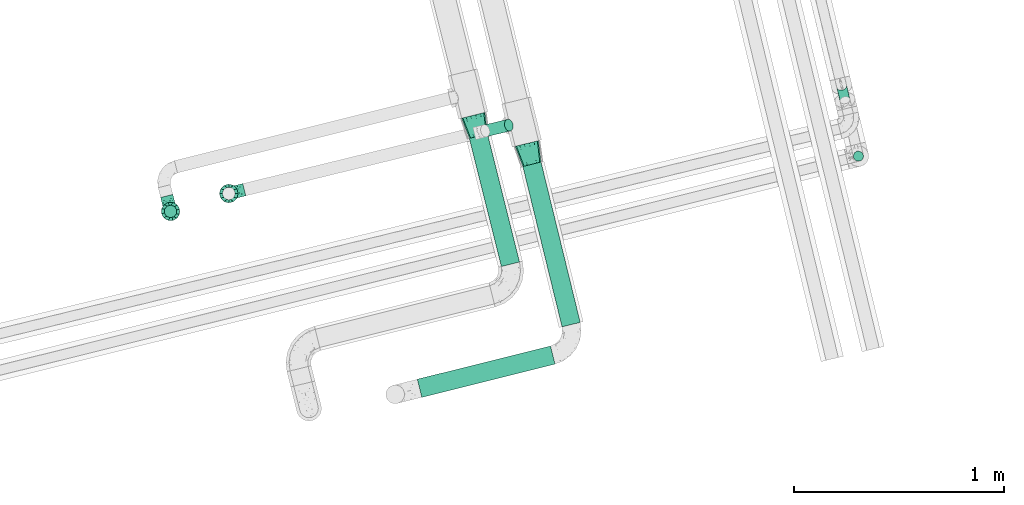
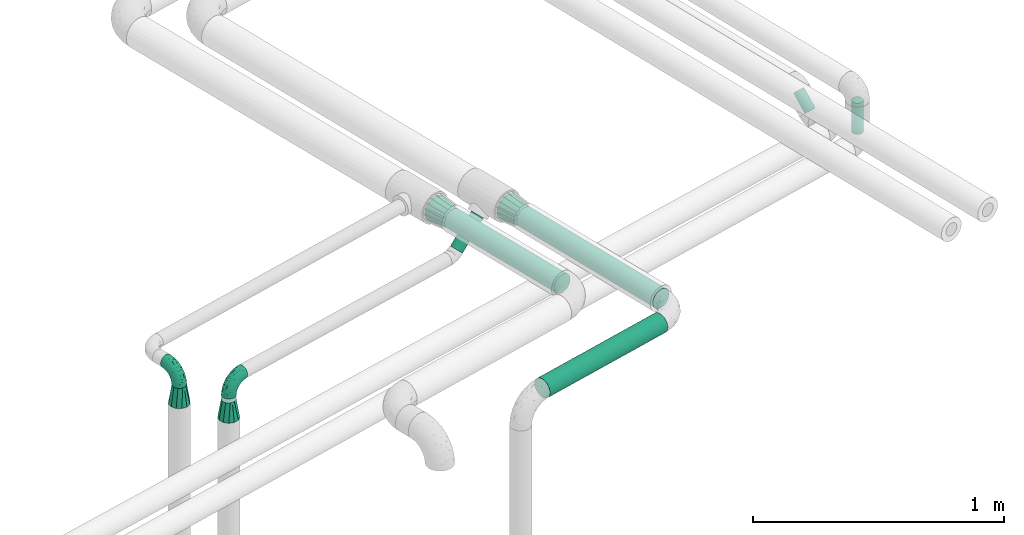
# One storey, part 49 of 93: 6 flow fittings, 6 flow segments.
"""IFC2X3 building model written with IfcOpenShell, lengths in millimetres."""

from ifc_helpers import new_model, entity, si_unit, converted_unit, derived_unit, direction, frame, origin, origin_2d_with_axis, place, context, subcontext, project, spatial, circle, extrude, faceted_brep, source, transform, mapped, material, type_object, type_shapes, element, save


model = new_model("IFC2X3")

# Units and contexts
model_context = context("Model", 3, precision=0.01, world=origin(), true_north=direction((6.12303176911189e-17, 1.0)))
body_context = subcontext(model_context, "Body", "Model", "MODEL_VIEW")
ifc_project = project(units=[si_unit("LENGTHUNIT", "METRE", prefix="MILLI"), si_unit("AREAUNIT", "SQUARE_METRE"), si_unit("VOLUMEUNIT", "CUBIC_METRE"), converted_unit("PLANEANGLEUNIT", "DEGREE", entity("IfcRatioMeasure", 0.0174532925199433), si_unit("PLANEANGLEUNIT", "RADIAN"), dimensions=[0, 0, 0, 0, 0, 0, 0]), si_unit("MASSUNIT", "GRAM", prefix="KILO"), derived_unit("MASSDENSITYUNIT", [(si_unit("MASSUNIT", "GRAM", prefix="KILO"), 1), (si_unit("LENGTHUNIT", "METRE"), -3)]), derived_unit("MOMENTOFINERTIAUNIT", [(si_unit("LENGTHUNIT", "METRE"), 4)]), si_unit("TIMEUNIT", "SECOND"), si_unit("FREQUENCYUNIT", "HERTZ"), si_unit("THERMODYNAMICTEMPERATUREUNIT", "DEGREE_CELSIUS"), derived_unit("THERMALTRANSMITTANCEUNIT", [(si_unit("MASSUNIT", "GRAM", prefix="KILO"), 1), (si_unit("THERMODYNAMICTEMPERATUREUNIT", "KELVIN"), -1), (si_unit("TIMEUNIT", "SECOND"), -3)]), derived_unit("VOLUMETRICFLOWRATEUNIT", [(si_unit("LENGTHUNIT", "METRE"), 3), (si_unit("TIMEUNIT", "SECOND"), -1)]), derived_unit("MASSFLOWRATEUNIT", [(si_unit("MASSUNIT", "GRAM", prefix="KILO"), 1), (si_unit("TIMEUNIT", "SECOND"), -1)]), derived_unit("ROTATIONALFREQUENCYUNIT", [(si_unit("TIMEUNIT", "SECOND"), -1)]), si_unit("ELECTRICCURRENTUNIT", "AMPERE"), si_unit("ELECTRICVOLTAGEUNIT", "VOLT"), si_unit("POWERUNIT", "WATT"), si_unit("FORCEUNIT", "NEWTON", prefix="KILO"), si_unit("ILLUMINANCEUNIT", "LUX"), si_unit("LUMINOUSFLUXUNIT", "LUMEN"), si_unit("LUMINOUSINTENSITYUNIT", "CANDELA"), derived_unit("USERDEFINED", [(si_unit("MASSUNIT", "GRAM", prefix="KILO"), -1), (si_unit("LENGTHUNIT", "METRE"), -2), (si_unit("TIMEUNIT", "SECOND"), 3), (si_unit("LUMINOUSFLUXUNIT", "LUMEN"), 1)]), derived_unit("LINEARVELOCITYUNIT", [(si_unit("LENGTHUNIT", "METRE"), 1), (si_unit("TIMEUNIT", "SECOND"), -1)]), si_unit("PRESSUREUNIT", "PASCAL"), derived_unit("USERDEFINED", [(si_unit("LENGTHUNIT", "METRE"), -2), (si_unit("MASSUNIT", "GRAM", prefix="KILO"), 1), (si_unit("TIMEUNIT", "SECOND"), -2)]), derived_unit("LINEARFORCEUNIT", [(si_unit("MASSUNIT", "GRAM", prefix="KILO"), 1), (si_unit("LENGTHUNIT", "METRE"), 1), (si_unit("TIMEUNIT", "SECOND"), -2), (si_unit("LENGTHUNIT", "METRE"), -1)]), derived_unit("PLANARFORCEUNIT", [(si_unit("MASSUNIT", "GRAM", prefix="KILO"), 1), (si_unit("LENGTHUNIT", "METRE"), 1), (si_unit("TIMEUNIT", "SECOND"), -2), (si_unit("LENGTHUNIT", "METRE"), -2)])], contexts=[model_context])

# Site, building, storey
site_placement = place(None, origin())
site = spatial("IfcSite", under=ifc_project, at=site_placement, CompositionType="ELEMENT")
building_placement = place(site_placement, origin())
building = spatial("IfcBuilding", under=site, at=building_placement, CompositionType="ELEMENT")
storey_placement = place(building_placement, frame((0.0, 0.0, -4200.0)))
storey = spatial("IfcBuildingStorey", under=building, at=storey_placement, CompositionType="ELEMENT", Elevation=-4200.0)

# Flow segments
pipe_segment_type_1 = type_object("IfcPipeSegmentType", PredefinedType="NOTDEFINED")
flow_segment_1_placement = place(storey_placement, frame((-16417.0, 9148.92, 2453.9)))
element("IfcFlowSegment", 1, at=flow_segment_1_placement, inside=storey, type_object=pipe_segment_type_1, context=body_context, shape_type="SweptSolid", body=[
    extrude(circle(Radius=44.5, at=origin_2d_with_axis()), frame((197.07, 12.37, 46.1), z_axis=(-0.242135671523204, 0.970242400937007, 0.0), x_axis=(-0.970242400937007, -0.242135671523204, 0.0)), (0.0, 0.0, 1.0), 628.967891638254),
])
flow_segment_2_placement = place(storey_placement, frame((-16162.32, 8861.59, 2454.51)))
element("IfcFlowSegment", 2, at=flow_segment_2_placement, inside=storey, type_object=pipe_segment_type_1, context=body_context, shape_type="SweptSolid", body=[
    extrude(circle(Radius=44.5, at=origin_2d_with_axis()), frame((231.43, 12.16, 46.1), z_axis=(-0.237382152141801, 0.971416344233783, 0.0), x_axis=(-0.971416344233783, -0.237382152141801, 0.0)), (0.0, 0.0, 1.0), 786.084760659508),
])
flow_segment_3_placement = place(storey_placement, frame((-16664.77, 8525.85, 2454.51)))
element("IfcFlowSegment", 3, at=flow_segment_3_placement, inside=storey, type_object=pipe_segment_type_1, context=body_context, shape_type="SweptSolid", body=[
    extrude(circle(Radius=44.5, at=origin_2d_with_axis()), frame((12.37, 44.77, 46.1), z_axis=(0.970244641056997, 0.242126695141572, 0.0), x_axis=(-0.242126695141572, 0.970244641056997, 0.0)), (0.0, 0.0, 1.0), 653.432264769607),
])
flow_segment_4_placement = place(storey_placement, frame((-16362.17, 9766.96, 2300.51)))
element("IfcFlowSegment", 4, at=flow_segment_4_placement, inside=storey, type_object=pipe_segment_type_1, context=body_context, shape_type="SweptSolid", body=[
    extrude(circle(Radius=28.5, at=origin_2d_with_axis()), frame((22.25, 29.58, 21.75), z_axis=(0.687533637537518, 0.16521954259235, 0.70710678118655), x_axis=(0.233655717903182, -0.972319394793269, 0.0)), (0.0, 0.0, 1.0), 163.157575528078),
])
pipe_segment_type_2 = type_object("IfcPipeSegmentType", PredefinedType="NOTDEFINED")
flow_segment_5_placement = place(storey_placement, frame((-14667.45, 9923.79, 2290.97)))
element("IfcFlowSegment", 5, at=flow_segment_5_placement, inside=storey, type_object=pipe_segment_type_2, context=body_context, shape_type="SweptSolid", body=[
    extrude(circle(Radius=24.0, at=origin_2d_with_axis()), frame((40.74, 18.99, 18.57), z_axis=(-0.165369921288888, 0.687497483001026, 0.707106781186662), x_axis=(0.972268264557574, 0.233868385495354, 0.0)), (0.0, 0.0, 1.0), 94.2010101267752),
])
flow_segment_6_placement = place(storey_placement, frame((-14588.48, 9650.21, 2349.84)))
element("IfcFlowSegment", 6, at=flow_segment_6_placement, inside=storey, type_object=pipe_segment_type_2, context=body_context, shape_type="SweptSolid", body=[
    extrude(circle(Radius=24.0, at=origin_2d_with_axis()), frame((25.6, 25.6, 0.0), z_axis=(0.0, 0.0, 1.0), x_axis=(-1.0, 0.0, 0.0)), (0.0, 0.0, 1.0), 151.958369439788),
])

# Flow fittings
ifc_material = material()
pipe_fitting_type_1 = type_object("IfcPipeFittingType", Name="ADSK_1", PredefinedType="NOTDEFINED", material=ifc_material)
shared_shape_1 = source(origin(), body_context, "Body", "Brep", [
    faceted_brep([(-76.0, 15.07, -26.11), (-76.0, 7.8, -29.12), (-76.0, 0.0, -30.15), (-76.0, -7.8, -29.12), (-76.0, -15.08, -26.11), (-76.0, -21.32, -21.32), (-76.0, -26.11, -15.08), (-76.0, -29.12, -7.8), (-76.0, -30.15, 0.0), (-76.0, -29.12, 7.8), (-76.0, -26.11, 15.07), (-76.0, -21.32, 21.32), (-76.0, -15.08, 26.11), (-76.0, -7.8, 29.12), (-76.0, 0.0, 30.15), (-76.0, 7.8, 29.12), (-76.0, 15.07, 26.11), (-76.0, 21.32, 21.32), (-76.0, 26.11, 15.07), (-76.0, 29.12, 7.8), (-76.0, 30.15, 0.0), (-76.0, 29.12, -7.8), (-76.0, 26.11, -15.08), (-76.0, 21.32, -21.32), (0.0, 76.0, -30.15), (-7.8, 76.0, -29.12), (-15.07, 76.0, -26.11), (-21.32, 76.0, -21.32), (-26.11, 76.0, -15.08), (-29.12, 76.0, -7.8), (-30.15, 76.0, 0.0), (-29.12, 76.0, 7.8), (-26.11, 76.0, 15.07), (-21.32, 76.0, 21.32), (-15.07, 76.0, 26.11), (-7.8, 76.0, 29.12), (0.0, 76.0, 30.15), (7.8, 76.0, 29.12), (15.08, 76.0, 26.11), (21.32, 76.0, 21.32), (26.11, 76.0, 15.07), (29.12, 76.0, 7.8), (30.15, 76.0, 0.0), (29.12, 76.0, -7.8), (26.11, 76.0, -15.08), (21.32, 76.0, -21.32), (15.08, 76.0, -26.11), (7.8, 76.0, -29.12), (10.79, 31.43, 21.07), (4.32, 31.7, 25.72), (1.65, 15.19, 19.92), (-61.17, -27.8, 0.0), (-51.1, -25.49, 9.84), (-56.14, -10.61, 27.27), (-31.7, -4.32, 25.72), (-39.75, 1.72, 29.41), (-43.2, -24.95, 0.0), (-1.86, 1.86, 0.0), (4.49, 7.65, 5.78), (-7.82, -4.61, 5.83), (-56.21, -22.79, 17.21), (-58.98, -3.38, 29.7), (-53.96, 5.6, 30.07), (-10.86, 10.86, 25.48), (-17.2, -2.6, 20.44), (-49.15, -16.01, 22.7), (-22.18, -14.24, 7.99), (-28.4, -17.42, 0.0), (-13.61, -9.88, 0.0), (-39.0, 23.48, 27.76), (-58.76, 12.54, 28.36), (-41.61, 15.41, 29.48), (16.01, 49.15, 22.7), (-58.55, 25.93, 19.53), (-51.53, 33.5, 13.51), (-64.92, 28.76, 12.4), (-7.48, 23.14, 28.25), (-1.72, 39.75, 29.41), (-12.04, 27.88, 29.88), (-63.91, 18.81, 24.52), (-11.63, 65.16, 28.18), (-4.97, 57.02, 30.05), (9.88, 13.61, 0.0), (-62.5, 31.74, 5.02), (-45.17, 30.98, 21.2), (-21.78, 9.76, 28.58), (10.61, 56.14, 27.27), (-32.09, 54.42, 13.26), (22.79, 56.21, 17.21), (15.38, 31.17, 15.63), (25.49, 51.1, 9.84), (21.84, 36.35, 5.92), (24.95, 43.2, 0.0), (3.38, 58.98, 29.7), (-31.17, -15.38, 15.63), (-39.39, 41.78, 15.45), (-34.56, 41.13, 20.79), (-39.81, -23.25, 5.49), (27.8, 61.17, 0.0), (-31.74, 62.5, 5.02), (-53.07, 36.29, 0.0), (-42.95, 42.95, 7.29), (-36.29, 53.07, 0.0), (-19.83, 58.51, 24.79), (-25.48, 60.2, 19.41), (-14.53, 50.96, 28.57), (-13.31, 37.09, 30.07), (-26.16, 40.06, 26.4), (-32.43, -10.35, 21.9), (17.42, 28.4, 0.0), (14.24, 22.18, 7.99), (-38.67, 9.72, 30.15), (-24.66, 17.36, 30.09), (-37.08, 31.49, 24.99), (-49.27, 22.83, 25.24), (-20.8, 38.81, 28.63), (-27.58, 27.58, 29.2), (-36.07, -20.23, 10.71), (-15.19, -6.16, 14.9), (6.6, 15.4, 14.49), (-2.51, 2.51, 11.35), (-65.16, 11.63, -28.18), (-49.15, -16.01, -22.7), (-57.02, 4.97, -30.05), (-25.93, 58.55, -19.53), (-33.5, 51.53, -13.51), (-28.76, 64.92, -12.4), (-60.2, 25.48, -19.41), (-58.51, 19.83, -24.79), (4.61, 7.82, -5.83), (-7.65, -4.49, -5.78), (-2.51, 2.51, -11.35), (-62.5, 31.74, -5.02), (-50.96, 14.53, -28.57), (-37.09, 13.31, -30.07), (-42.95, 42.95, -7.29), (25.49, 51.1, -9.84), (22.79, 56.21, -17.21), (-40.06, 26.16, -26.4), (3.38, 58.98, -29.7), (-5.6, 53.96, -30.07), (-27.88, 12.04, -29.88), (-9.76, 21.78, -28.58), (-23.14, 7.48, -28.25), (-51.1, -25.49, -9.84), (15.38, 31.17, -15.63), (16.01, 49.15, -22.7), (-23.48, 39.0, -27.76), (-12.54, 58.76, -28.36), (-15.41, 41.61, -29.48), (-56.21, -22.79, -17.21), (-9.72, 38.67, -30.15), (-17.36, 24.66, -30.09), (-22.18, -14.24, -7.99), (-41.13, 34.56, -20.79), (-31.74, 62.5, -5.02), (-58.98, -3.38, -29.7), (-31.17, -15.38, -15.63), (-56.14, -10.61, -27.27), (14.24, 22.18, -7.99), (23.25, 39.81, -5.49), (-31.49, 37.08, -24.99), (-15.19, -6.16, -14.9), (1.65, 15.19, -19.92), (-18.81, 63.91, -24.52), (-32.59, -11.62, -20.84), (-31.7, -4.32, -25.72), (-17.2, -2.6, -20.44), (-39.75, 1.72, -29.41), (-54.42, 32.09, -13.26), (-30.98, 45.17, -21.2), (10.61, 56.14, -27.27), (10.23, 31.31, -21.52), (4.32, 31.7, -25.72), (-41.78, 39.39, -15.45), (-1.72, 39.75, -29.41), (-36.35, -21.84, -5.92), (-22.83, 49.27, -25.24), (-38.81, 20.8, -28.63), (-27.58, 27.58, -29.2), (-10.86, 10.86, -25.48), (20.23, 36.07, -10.71), (6.6, 15.4, -14.49)], [[[0, 1, 2, 3, 4, 5, 6, 7, 8, 9, 10, 11, 12, 13, 14, 15, 16, 17, 18, 19, 20, 21, 22, 23]], [[24, 25, 26, 27, 28, 29, 30, 31, 32, 33, 34, 35, 36, 37, 38, 39, 40, 41, 42, 43, 44, 45, 46, 47]], [[48, 49, 50]], [[51, 52, 9]], [[53, 54, 55]], [[9, 52, 10]], [[56, 52, 51]], [[57, 58, 59]], [[11, 10, 60]], [[14, 61, 62]], [[63, 54, 64]], [[65, 12, 11]], [[65, 53, 12]], [[66, 67, 68]], [[69, 70, 71]], [[72, 39, 38]], [[73, 74, 75]], [[15, 70, 16]], [[76, 77, 78]], [[16, 79, 17]], [[13, 61, 14]], [[35, 80, 81]], [[14, 62, 15]], [[17, 73, 18]], [[57, 82, 58]], [[20, 19, 83]], [[75, 19, 18]], [[70, 15, 62]], [[73, 84, 74]], [[78, 85, 76]], [[38, 86, 72]], [[32, 31, 87]], [[88, 89, 90]], [[91, 92, 90]], [[72, 86, 49]], [[36, 93, 37]], [[75, 83, 19]], [[36, 35, 81]], [[60, 94, 65]], [[40, 90, 41]], [[95, 96, 87]], [[88, 90, 40]], [[66, 97, 67]], [[90, 98, 41]], [[40, 39, 88]], [[99, 31, 30]], [[20, 83, 100]], [[101, 102, 100]], [[52, 60, 10]], [[102, 99, 30]], [[96, 103, 104]], [[83, 101, 100]], [[12, 53, 13]], [[104, 103, 33]], [[105, 106, 81]], [[107, 105, 103]], [[64, 54, 108]], [[80, 103, 105]], [[80, 35, 34]], [[34, 33, 103]], [[86, 38, 37]], [[109, 110, 82]], [[71, 111, 112]], [[69, 107, 113]], [[79, 73, 17]], [[114, 113, 84]], [[33, 32, 104]], [[115, 107, 116]], [[105, 115, 106]], [[93, 81, 77]], [[54, 53, 65]], [[61, 53, 55]], [[108, 94, 64]], [[54, 63, 85]], [[93, 86, 37]], [[77, 76, 49]], [[77, 49, 86]], [[49, 63, 50]], [[60, 52, 117]], [[65, 11, 60]], [[39, 72, 88]], [[89, 88, 72]], [[71, 70, 62]], [[79, 70, 114]], [[103, 96, 107]], [[69, 113, 114]], [[112, 106, 116]], [[77, 81, 106]], [[112, 116, 71]], [[112, 55, 85]], [[64, 50, 63]], [[57, 59, 68]], [[32, 87, 104]], [[96, 104, 87]], [[94, 118, 64]], [[50, 119, 89]], [[50, 64, 118]], [[50, 89, 48]], [[81, 93, 36]], [[86, 93, 77]], [[53, 61, 13]], [[62, 61, 55]], [[71, 62, 111]], [[69, 71, 116]], [[95, 101, 74]], [[99, 101, 87]], [[118, 66, 59]], [[117, 97, 66]], [[117, 66, 94]], [[91, 89, 110]], [[91, 110, 109]], [[110, 89, 119]], [[9, 8, 51]], [[98, 90, 92]], [[98, 42, 41]], [[101, 83, 74]], [[101, 99, 102]], [[87, 31, 99]], [[62, 55, 111]], [[55, 112, 111]], [[107, 69, 116]], [[70, 69, 114]], [[107, 96, 113]], [[84, 113, 96]], [[84, 96, 95]], [[114, 84, 73]], [[70, 79, 16]], [[73, 79, 114]], [[54, 85, 55]], [[76, 85, 63]], [[49, 76, 63]], [[77, 106, 78]], [[106, 112, 78]], [[85, 78, 112]], [[73, 75, 18]], [[83, 75, 74]], [[103, 80, 34]], [[81, 80, 105]], [[101, 95, 87]], [[84, 95, 74]], [[106, 115, 116]], [[105, 107, 115]], [[120, 59, 58]], [[82, 110, 58]], [[119, 58, 110]], [[118, 59, 120]], [[66, 68, 59]], [[54, 65, 108]], [[94, 108, 65]], [[66, 118, 94]], [[50, 118, 120]], [[50, 120, 119]], [[119, 120, 58]], [[89, 72, 48]], [[49, 48, 72]], [[60, 117, 94]], [[117, 52, 97]], [[52, 56, 97]], [[67, 97, 56]], [[92, 91, 109]], [[89, 91, 90]], [[121, 1, 0]], [[122, 5, 4]], [[2, 1, 123]], [[124, 125, 126]], [[127, 128, 23]], [[129, 130, 131]], [[100, 132, 20]], [[133, 134, 123]], [[135, 100, 102]], [[136, 137, 44]], [[133, 128, 138]], [[24, 139, 140]], [[141, 142, 143]], [[121, 128, 133]], [[6, 144, 7]], [[137, 145, 146]], [[144, 51, 7]], [[147, 148, 149]], [[144, 6, 150]], [[149, 151, 152]], [[153, 68, 67]], [[154, 128, 127]], [[30, 155, 102]], [[43, 42, 98]], [[156, 3, 2]], [[157, 144, 150]], [[158, 4, 3]], [[24, 140, 25]], [[155, 135, 102]], [[159, 160, 109]], [[30, 29, 155]], [[147, 138, 161]], [[27, 124, 28]], [[57, 129, 82]], [[162, 163, 131]], [[27, 26, 164]], [[148, 26, 25]], [[165, 166, 167]], [[24, 47, 139]], [[143, 168, 141]], [[22, 21, 169]], [[125, 124, 170]], [[148, 25, 140]], [[46, 146, 171]], [[158, 122, 4]], [[0, 23, 128]], [[1, 121, 123]], [[109, 82, 159]], [[45, 44, 137]], [[146, 46, 45]], [[136, 43, 98]], [[132, 21, 20]], [[136, 98, 92]], [[172, 173, 146]], [[46, 171, 47]], [[43, 136, 44]], [[174, 154, 169]], [[171, 173, 175]], [[6, 5, 150]], [[126, 29, 28]], [[176, 56, 144]], [[122, 158, 166]], [[164, 124, 27]], [[177, 161, 170]], [[23, 22, 127]], [[178, 138, 179]], [[133, 178, 134]], [[156, 123, 168]], [[156, 158, 3]], [[168, 143, 166]], [[168, 166, 158]], [[166, 180, 167]], [[173, 171, 146]], [[139, 171, 175]], [[172, 145, 163]], [[173, 180, 142]], [[5, 122, 150]], [[157, 150, 122]], [[137, 136, 181]], [[146, 45, 137]], [[149, 148, 140]], [[164, 148, 177]], [[128, 154, 138]], [[147, 161, 177]], [[152, 134, 179]], [[168, 123, 134]], [[152, 179, 149]], [[152, 175, 142]], [[57, 130, 129]], [[157, 165, 167]], [[22, 169, 127]], [[154, 127, 169]], [[163, 167, 180]], [[162, 157, 167]], [[173, 163, 180]], [[182, 163, 145]], [[123, 156, 2]], [[158, 156, 168]], [[171, 139, 47]], [[140, 139, 175]], [[149, 140, 151]], [[147, 149, 179]], [[174, 135, 125]], [[132, 135, 169]], [[176, 157, 153]], [[176, 153, 67]], [[153, 157, 162]], [[182, 159, 129]], [[181, 160, 159]], [[181, 159, 145]], [[51, 144, 56]], [[51, 8, 7]], [[135, 132, 100]], [[169, 21, 132]], [[126, 155, 29]], [[135, 155, 125]], [[140, 175, 151]], [[175, 152, 151]], [[138, 147, 179]], [[148, 147, 177]], [[138, 154, 161]], [[170, 161, 154]], [[170, 154, 174]], [[177, 170, 124]], [[148, 164, 26]], [[124, 164, 177]], [[173, 142, 175]], [[143, 142, 180]], [[166, 143, 180]], [[168, 134, 141]], [[134, 152, 141]], [[142, 141, 152]], [[124, 126, 28]], [[155, 126, 125]], [[128, 121, 0]], [[123, 121, 133]], [[135, 174, 169]], [[170, 174, 125]], [[134, 178, 179]], [[133, 138, 178]], [[130, 153, 162]], [[68, 153, 130]], [[57, 68, 130]], [[182, 129, 131]], [[159, 82, 129]], [[157, 122, 165]], [[166, 165, 122]], [[163, 162, 167]], [[162, 131, 130]], [[145, 172, 146]], [[163, 173, 172]], [[159, 182, 145]], [[131, 163, 182]], [[56, 176, 67]], [[157, 176, 144]], [[137, 181, 145]], [[181, 136, 160]], [[136, 92, 160]], [[109, 160, 92]]]),
])
type_shapes(pipe_fitting_type_1, [shared_shape_1])
for number, where, z_axis, x_axis, name in (
    (7, (-17838.46, 9412.84, 2500.0), (0.970295726275993, 0.241921895599683, 0.0), (0.241921895599683, -0.970295726275993, 0.0), "ADSK_1"),
    (8, (-17561.15, 9498.18, 2300.0), (-0.237498617900138, 0.971387876440469, 0.0), (0.0, 0.0, 1.0), "ADSK_1"),
):
    element("IfcFlowFitting", number, at=place(storey_placement, frame(where, z_axis=z_axis, x_axis=x_axis)), inside=storey, type_object=pipe_fitting_type_1, material=ifc_material, Name=name, ObjectType="ADSK_1", context=body_context, shape_type="MappedRepresentation", body=[
        mapped(shared_shape_1, transform((0.0, 0.0, 0.0), scale=1.0)),
    ])
pipe_fitting_type_2 = type_object("IfcPipeFittingType", Name="ADSK_1", PredefinedType="NOTDEFINED", material=ifc_material)
shared_shape_2 = source(origin(), body_context, "Body", "Brep", [
    faceted_brep([(89.0, -44.45, 0.0), (89.0, -42.1, -8.76), (89.0, -38.49, -22.22), (89.0, -30.36, -30.36), (89.0, -22.23, -38.49), (89.0, -11.11, -41.47), (89.0, 0.0, -44.45), (89.0, 11.11, -41.47), (89.0, 22.22, -38.49), (89.0, 30.36, -30.36), (89.0, 38.49, -22.22), (89.0, 42.1, -8.76), (89.0, 44.45, 0.0), (89.0, 42.1, 8.76), (89.0, 38.49, 22.23), (89.0, 30.36, 30.36), (89.0, 22.22, 38.49), (89.0, 11.11, 41.47), (89.0, 0.0, 44.45), (89.0, -11.11, 41.47), (89.0, -22.23, 38.49), (89.0, -30.36, 30.36), (89.0, -38.49, 22.23), (89.0, -42.1, 8.76), (0.0, 30.15, 0.0), (0.0, 27.27, -8.86), (0.0, 24.39, -17.72), (0.0, 16.85, -23.2), (0.0, 9.32, -28.67), (0.0, 0.0, -28.67), (0.0, -9.32, -28.67), (0.0, -16.85, -23.2), (0.0, -24.39, -17.72), (0.0, -27.27, -8.86), (0.0, -30.15, 0.0), (0.0, -27.27, 8.86), (0.0, -24.39, 17.72), (0.0, -16.85, 23.2), (0.0, -9.32, 28.67), (0.0, 0.0, 28.67), (0.0, 9.32, 28.67), (0.0, 16.85, 23.2), (0.0, 24.39, 17.72), (0.0, 27.27, 8.86)], [[[0, 1, 2, 3, 4, 5, 6, 7, 8, 9, 10, 11, 12, 13, 14, 15, 16, 17, 18, 19, 20, 21, 22, 23]], [[24, 25, 26, 27, 28, 29, 30, 31, 32, 33, 34, 35, 36, 37, 38, 39, 40, 41, 42, 43]], [[2, 33, 32]], [[28, 7, 29]], [[29, 5, 30]], [[24, 12, 11]], [[3, 32, 31]], [[34, 1, 0]], [[1, 34, 33]], [[8, 28, 27]], [[2, 1, 33]], [[31, 4, 3]], [[2, 32, 3]], [[11, 25, 24]], [[26, 10, 9]], [[10, 25, 11]], [[28, 8, 7]], [[27, 26, 9]], [[26, 25, 10]], [[31, 30, 4]], [[8, 27, 9]], [[29, 7, 6]], [[5, 29, 6]], [[5, 4, 30]], [[14, 43, 42]], [[38, 19, 39]], [[39, 17, 40]], [[34, 0, 23]], [[15, 42, 41]], [[24, 13, 12]], [[13, 24, 43]], [[20, 38, 37]], [[14, 13, 43]], [[41, 16, 15]], [[14, 42, 15]], [[23, 35, 34]], [[36, 22, 21]], [[22, 35, 23]], [[38, 20, 19]], [[37, 36, 21]], [[36, 35, 22]], [[41, 40, 16]], [[20, 37, 21]], [[39, 19, 18]], [[17, 39, 18]], [[17, 16, 40]]]),
])
type_shapes(pipe_fitting_type_2, [shared_shape_2])
flow_fitting_1_placement = place(storey_placement, frame((-17561.15, 9498.18, 2204.0), z_axis=(0.0, 1.0, 0.0), x_axis=(0.0, 0.0, -1.0)))
element("IfcFlowFitting", 9, at=flow_fitting_1_placement, inside=storey, type_object=pipe_fitting_type_2, material=ifc_material, Name="ADSK_1", ObjectType="ADSK_1", context=body_context, shape_type="MappedRepresentation", body=[
    mapped(shared_shape_2, transform((0.0, 0.0, 0.0), scale=1.0)),
])
pipe_fitting_type_3 = type_object("IfcPipeFittingType", Name="ADSK_1", PredefinedType="NOTDEFINED", material=ifc_material)
shared_shape_3 = source(origin(), body_context, "Body", "Brep", [
    faceted_brep([(89.0, 38.49, -22.22), (89.0, 42.1, -8.76), (89.0, 44.45, 0.0), (89.0, 42.1, 8.76), (89.0, 38.49, 22.23), (89.0, 30.36, 30.36), (89.0, 22.23, 38.49), (89.0, 11.11, 41.47), (89.0, 0.0, 44.45), (89.0, -11.11, 41.47), (89.0, -22.22, 38.49), (89.0, -30.36, 30.36), (89.0, -38.49, 22.23), (89.0, -42.1, 8.76), (89.0, -44.45, 0.0), (89.0, -42.1, -8.76), (89.0, -38.49, -22.22), (89.0, -30.36, -30.36), (89.0, -22.22, -38.49), (89.0, -11.11, -41.47), (89.0, 0.0, -44.45), (89.0, 11.11, -41.47), (89.0, 22.23, -38.49), (89.0, 30.36, -30.36), (0.0, -24.39, -17.72), (0.0, -27.27, -8.86), (0.0, -30.15, 0.0), (0.0, -27.27, 8.86), (0.0, -24.39, 17.72), (0.0, -16.85, 23.2), (0.0, -9.32, 28.67), (0.0, 0.0, 28.67), (0.0, 9.32, 28.67), (0.0, 16.85, 23.2), (0.0, 24.39, 17.72), (0.0, 27.27, 8.86), (0.0, 30.15, 0.0), (0.0, 27.27, -8.86), (0.0, 24.39, -17.72), (0.0, 16.85, -23.2), (0.0, 9.32, -28.67), (0.0, 0.0, -28.67), (0.0, -9.32, -28.67), (0.0, -16.85, -23.2)], [[[0, 1, 2, 3, 4, 5, 6, 7, 8, 9, 10, 11, 12, 13, 14, 15, 16, 17, 18, 19, 20, 21, 22, 23]], [[24, 25, 26, 27, 28, 29, 30, 31, 32, 33, 34, 35, 36, 37, 38, 39, 40, 41, 42, 43]], [[38, 37, 0]], [[41, 19, 42]], [[40, 21, 41]], [[15, 14, 26]], [[39, 38, 23]], [[2, 1, 36]], [[37, 36, 1]], [[43, 42, 18]], [[37, 1, 0]], [[23, 22, 39]], [[23, 38, 0]], [[26, 25, 15]], [[17, 16, 24]], [[15, 25, 16]], [[19, 18, 42]], [[17, 24, 43]], [[16, 25, 24]], [[22, 40, 39]], [[17, 43, 18]], [[20, 19, 41]], [[20, 41, 21]], [[40, 22, 21]], [[28, 27, 12]], [[31, 7, 32]], [[30, 9, 31]], [[3, 2, 36]], [[29, 28, 11]], [[14, 13, 26]], [[27, 26, 13]], [[33, 32, 6]], [[27, 13, 12]], [[11, 10, 29]], [[11, 28, 12]], [[36, 35, 3]], [[5, 4, 34]], [[3, 35, 4]], [[7, 6, 32]], [[5, 34, 33]], [[4, 35, 34]], [[10, 30, 29]], [[5, 33, 6]], [[8, 7, 31]], [[8, 31, 9]], [[30, 10, 9]]]),
])
type_shapes(pipe_fitting_type_3, [shared_shape_3])
flow_fitting_2_placement = place(storey_placement, frame((-17838.46, 9412.84, 2424.0), z_axis=(0.241921895599681, -0.970295726275993, 0.0), x_axis=(0.0, 0.0, -1.0)))
element("IfcFlowFitting", 10, at=flow_fitting_2_placement, inside=storey, type_object=pipe_fitting_type_3, material=ifc_material, Name="ADSK_1", ObjectType="ADSK_1", context=body_context, shape_type="MappedRepresentation", body=[
    mapped(shared_shape_3, transform((0.0, 0.0, 0.0), scale=1.0)),
])
pipe_fitting_type_4 = type_object("IfcPipeFittingType", Name="ADSK_1", PredefinedType="NOTDEFINED", material=ifc_material)
shared_shape_4 = source(origin(), body_context, "Body", "Brep", [
    faceted_brep([(102.0, -30.36, 30.36), (102.0, -38.49, 22.23), (102.0, -41.47, 11.11), (102.0, -44.45, 0.0), (102.0, -41.47, -11.11), (102.0, -38.49, -22.22), (102.0, -30.36, -30.36), (102.0, -22.23, -38.49), (102.0, -11.11, -41.47), (102.0, 0.0, -44.45), (102.0, 11.11, -41.47), (102.0, 22.22, -38.49), (102.0, 30.36, -30.36), (102.0, 38.49, -22.22), (102.0, 41.47, -11.11), (102.0, 44.45, 0.0), (102.0, 41.47, 11.11), (102.0, 38.49, 22.23), (102.0, 30.36, 30.36), (102.0, 22.22, 38.49), (102.0, 11.11, 41.47), (102.0, 0.0, 44.45), (102.0, -11.11, 41.47), (102.0, -22.23, 38.49), (0.0, 24.17, 50.2), (0.0, 35.63, 44.68), (0.0, 43.56, 34.74), (0.0, 51.49, 24.8), (0.0, 54.32, 12.4), (0.0, 57.15, 0.0), (0.0, 54.32, -12.4), (0.0, 51.49, -24.8), (0.0, 43.56, -34.74), (0.0, 35.63, -44.68), (0.0, 24.17, -50.2), (0.0, 12.72, -55.72), (0.0, 0.0, -55.72), (0.0, -12.72, -55.72), (0.0, -24.17, -50.2), (0.0, -35.63, -44.68), (0.0, -43.56, -34.74), (0.0, -51.49, -24.8), (0.0, -54.32, -12.4), (0.0, -57.15, 0.0), (0.0, -54.32, 12.4), (0.0, -51.49, 24.8), (0.0, -43.56, 34.74), (0.0, -35.63, 44.68), (0.0, -24.17, 50.2), (0.0, -12.72, 55.72), (0.0, 0.0, 55.72), (0.0, 12.72, 55.72)], [[[0, 1, 2, 3, 4, 5, 6, 7, 8, 9, 10, 11, 12, 13, 14, 15, 16, 17, 18, 19, 20, 21, 22, 23]], [[24, 25, 26, 27, 28, 29, 30, 31, 32, 33, 34, 35, 36, 37, 38, 39, 40, 41, 42, 43, 44, 45, 46, 47, 48, 49, 50, 51]], [[14, 31, 30]], [[42, 3, 43]], [[32, 31, 13]], [[13, 31, 14]], [[34, 10, 35]], [[3, 42, 4]], [[12, 11, 33]], [[9, 37, 36, 35]], [[7, 39, 38]], [[39, 7, 6]], [[38, 8, 7]], [[34, 33, 11]], [[10, 9, 35]], [[40, 5, 41]], [[12, 33, 32]], [[15, 30, 29]], [[38, 37, 8]], [[15, 14, 30]], [[41, 5, 4]], [[5, 40, 6]], [[13, 12, 32]], [[10, 34, 11]], [[37, 9, 8]], [[40, 39, 6]], [[42, 41, 4]], [[2, 45, 44]], [[28, 15, 29]], [[46, 45, 1]], [[1, 45, 2]], [[48, 22, 49]], [[15, 28, 16]], [[0, 23, 47]], [[21, 51, 50, 49]], [[19, 25, 24]], [[25, 19, 18]], [[24, 20, 19]], [[48, 47, 23]], [[22, 21, 49]], [[26, 17, 27]], [[0, 47, 46]], [[3, 44, 43]], [[24, 51, 20]], [[3, 2, 44]], [[27, 17, 16]], [[17, 26, 18]], [[1, 0, 46]], [[22, 48, 23]], [[51, 21, 20]], [[26, 25, 18]], [[28, 27, 16]]]),
])
type_shapes(pipe_fitting_type_4, [shared_shape_4])
for number, where, z_axis, x_axis, name in (
    (11, (-16141.71, 9736.45, 2500.61), (0.0, 0.0, 1.0), (0.237382152141796, -0.971416344233784, 0.0), "ADSK_1"),
    (12, (-16396.93, 9870.51, 2500.0), (0.0, 0.0, 1.0), (0.242135671523188, -0.970242400937011, 0.0), "ADSK_1"),
):
    element("IfcFlowFitting", number, at=place(storey_placement, frame(where, z_axis=z_axis, x_axis=x_axis)), inside=storey, type_object=pipe_fitting_type_4, material=ifc_material, Name=name, ObjectType="ADSK_1", context=body_context, shape_type="MappedRepresentation", body=[
        mapped(shared_shape_4, transform((0.0, 0.0, 0.0), scale=1.0)),
    ])

save(model, "model.ifc")
